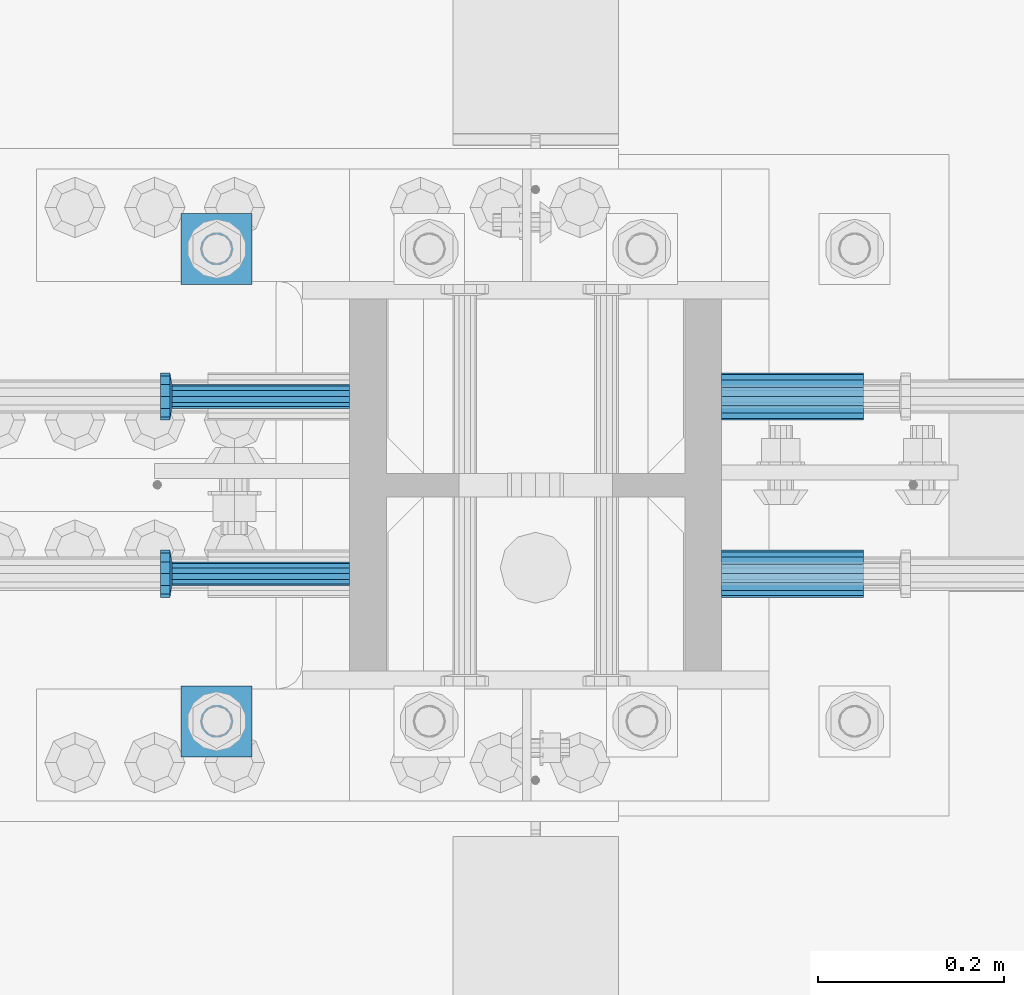
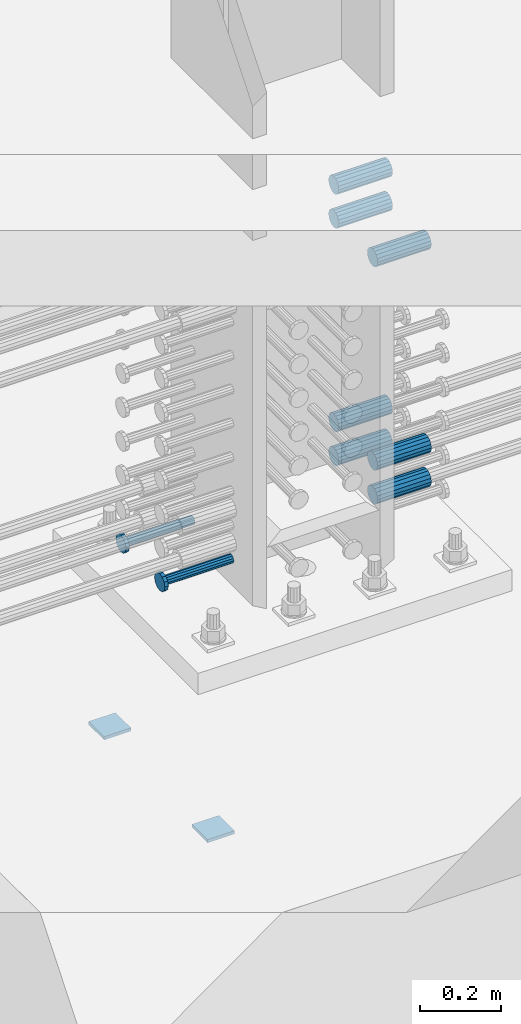
# One storey, part 1239 of 1763: 11 beams, 2 elements without a shape of their own.
"""IFC2X3 building model written with IfcOpenShell, lengths in millimetres."""

from ifc_helpers import new_model, si_unit, frame, origin_with_axes, place, context, subcontext, project, spatial, faceted_brep, material, type_object, element, aggregate, save


model = new_model("IFC2X3")

# Units and contexts
model_context = context("Model", 3, precision=1e-05, world=origin_with_axes())
body_context = subcontext(model_context, "Body", "Model", "MODEL_VIEW")
ifc_project = project(units=[si_unit("LENGTHUNIT", "METRE", prefix="MILLI"), si_unit("AREAUNIT", "SQUARE_METRE"), si_unit("VOLUMEUNIT", "CUBIC_METRE"), si_unit("MASSUNIT", "GRAM", prefix="KILO"), si_unit("TIMEUNIT", "SECOND"), si_unit("PLANEANGLEUNIT", "RADIAN"), si_unit("SOLIDANGLEUNIT", "STERADIAN"), si_unit("THERMODYNAMICTEMPERATUREUNIT", "DEGREE_CELSIUS"), si_unit("LUMINOUSINTENSITYUNIT", "LUMEN")], contexts=[model_context])

# Site, building, storey
site_placement = place(None, origin_with_axes())
site = spatial("IfcSite", under=ifc_project, at=site_placement, CompositionType="ELEMENT")
building_placement = place(site_placement, origin_with_axes())
building = spatial("IfcBuilding", under=site, at=building_placement, Name="Undefined", CompositionType="ELEMENT")
storey_placement = place(building_placement, origin_with_axes())
storey = spatial("IfcBuildingStorey", under=building, at=storey_placement, Name="Undefined", CompositionType="ELEMENT", Elevation=0.0)

# Assembly, beams
assembly_1_placement = place(storey_placement, origin_with_axes())
assembly_1 = element("IfcElementAssembly", 1, at=assembly_1_placement, inside=storey, Name="TEMPLATE", AssemblyPlace="NOTDEFINED", PredefinedType="RIGID_FRAME")
ifc_material_1 = material(Name="STEEL/A36")
beam_type_1 = type_object("IfcBeamType", PredefinedType="NOTDEFINED")
beam_1_placement = place(assembly_1_placement, frame((-35254.637273698, 203.199999999951, 3348.0375), z_axis=(0.0, 1.0, 0.0), x_axis=(-1.0, 0.0, 0.0)))
beam_1 = element("IfcBeam", 2, at=beam_1_placement, type_object=beam_type_1, material=ifc_material_1, Name="WASHER PLATE", context=body_context, shape_type="Brep", body=[
    faceted_brep([(0.0, 4.76249999999709, -38.1000000000004), (0.0, 4.76249999999709, 38.1000000000004), (76.2000000000007, 4.76249999999982, 38.0999999999985), (76.2000000000007, 4.76249999999982, -38.0999999999985), (0.0, -4.76249999999709, 38.1000000000004), (76.2000000000007, -4.76249999999982, 38.0999999999985), (0.0, -4.76249999999709, -38.1000000000004), (76.2000000000007, -4.76249999999982, -38.0999999999985)], [[[0, 1, 2, 3]], [[1, 4, 5, 2]], [[4, 6, 7, 5]], [[6, 0, 3, 7]], [[5, 7, 3, 2]], [[6, 4, 1, 0]]]),
])
beam_2_placement = place(assembly_1_placement, frame((-35254.637273698, 711.199999999951, 3348.0375), z_axis=(0.0, 1.0, 0.0), x_axis=(-1.0, 0.0, 0.0)))
beam_2 = element("IfcBeam", 3, at=beam_2_placement, type_object=beam_type_1, material=ifc_material_1, Name="WASHER PLATE", context=body_context, shape_type="Brep", body=[
    faceted_brep([(0.0, 4.76249999999709, -38.1000000000004), (0.0, 4.76249999999709, 38.1000000000004), (76.2000000000007, 4.76249999999982, 38.0999999999985), (76.2000000000007, 4.76249999999982, -38.0999999999985), (0.0, -4.76249999999709, 38.1000000000004), (76.2000000000007, -4.76249999999982, 38.0999999999985), (0.0, -4.76249999999709, -38.1000000000004), (76.2000000000007, -4.76249999999982, -38.0999999999985)], [[[0, 1, 2, 3]], [[1, 4, 5, 2]], [[4, 6, 7, 5]], [[6, 0, 3, 7]], [[5, 7, 3, 2]], [[6, 4, 1, 0]]]),
])
aggregate(assembly_1, [beam_1, beam_2])

assembly_2_placement = place(storey_placement, origin_with_axes())
assembly_2 = element("IfcElementAssembly", 4, at=assembly_2_placement, inside=storey, Name="COLUMN", AssemblyPlace="NOTDEFINED", PredefinedType="RIGID_FRAME")
ifc_material_2 = material(Name="STEEL/A706-GR.80")
beam_type_2 = type_object("IfcBeamType", PredefinedType="NOTDEFINED")
beam_3_placement = place(assembly_2_placement, frame((-34749.8122049617, 552.450000000255, 4063.99999999999), z_axis=(0.0, 0.0, 1.0), x_axis=(1.0, 0.0, 0.0)))
beam_3 = element("IfcBeam", 5, at=beam_3_placement, type_object=beam_type_2, material=ifc_material_2, Name="HALF COUPLER", context=body_context, shape_type="Brep", body=[
    faceted_brep([(0.0, -25.4000000000015, 0.0), (0.0, -23.466540125788, -9.72015918207308), (152.400103102711, -23.466540125788, -9.72015918207308), (152.400103102711, -25.4000000000015, 0.0), (0.0, -17.9605122421381, -17.9605122421385), (152.400103102711, -17.9605122421381, -17.9605122421385), (0.0, -9.72015918207398, -23.4665401257867), (152.400103102711, -9.72015918207398, -23.4665401257867), (0.0, 0.0, -25.4000000000001), (152.400103102711, 0.0, -25.4000000000001), (0.0, 9.72015918207398, -23.4665401257867), (152.400103102711, 9.72015918207398, -23.4665401257867), (0.0, 17.9605122421381, -17.9605122421385), (152.400103102711, 17.9605122421381, -17.9605122421385), (0.0, 23.466540125788, -9.72015918207308), (152.400103102711, 23.466540125788, -9.72015918207308), (0.0, 25.4000000000015, 0.0), (152.400103102711, 25.4000000000015, 0.0), (0.0, 23.466540125788, 9.72015918207308), (152.400103102711, 23.466540125788, 9.72015918207308), (0.0, 17.9605122421381, 17.9605122421385), (152.400103102711, 17.9605122421381, 17.9605122421385), (0.0, 9.72015918207398, 23.4665401257867), (152.400103102711, 9.72015918207398, 23.4665401257867), (0.0, 0.0, 25.4000000000001), (152.400103102711, 0.0, 25.4000000000001), (0.0, -9.72015918207398, 23.4665401257867), (152.400103102711, -9.72015918207398, 23.4665401257867), (0.0, -17.9605122421381, 17.9605122421385), (152.400103102711, -17.9605122421381, 17.9605122421385), (0.0, -23.466540125788, 9.72015918207308), (152.400103102711, -23.466540125788, 9.72015918207308)], [[[0, 1, 2, 3]], [[1, 4, 5, 2]], [[4, 6, 7, 5]], [[6, 8, 9, 7]], [[8, 10, 11, 9]], [[10, 12, 13, 11]], [[12, 14, 15, 13]], [[14, 16, 17, 15]], [[16, 18, 19, 17]], [[18, 20, 21, 19]], [[20, 22, 23, 21]], [[22, 24, 25, 23]], [[24, 26, 27, 25]], [[26, 28, 29, 27]], [[28, 30, 31, 29]], [[30, 0, 3, 31]], [[5, 7, 9, 11, 13, 15, 17, 19, 21, 23, 25, 27, 29, 31, 3, 2]], [[30, 28, 26, 24, 22, 20, 18, 16, 14, 12, 10, 8, 6, 4, 1, 0]]]),
])
beam_4_placement = place(assembly_2_placement, frame((-34749.8122736235, 361.950000000843, 4063.99999999999), z_axis=(0.0, 0.0, 1.0), x_axis=(1.0, 0.0, 0.0)))
beam_4 = element("IfcBeam", 6, at=beam_4_placement, type_object=beam_type_2, material=ifc_material_2, Name="HALF COUPLER F", context=body_context, shape_type="Brep", body=[
    faceted_brep([(32.7659999999996, -8.95349999999962, -15.507916905568), (32.7659999999996, 0.0, -17.9070000000002), (32.7659999999996, 8.95349999999962, -15.507916905568), (32.7659999999996, 15.507916905568, -8.95350000000008), (32.7659999999996, 17.9069999999992, 0.0), (32.7659999999996, 15.507916905568, 8.95350000000008), (32.7659999999996, 8.95349999999962, 15.507916905568), (32.7659999999996, 0.0, 17.9070000000002), (32.7659999999996, -8.95349999999962, 15.507916905568), (32.7659999999996, -15.507916905568, 8.95350000000008), (32.7659999999996, -17.9069999999992, 0.0), (32.7659999999996, -15.507916905568, -8.95350000000008), (152.400103102711, -15.507916905568, 8.95350000000008), (152.400103102711, -8.95349999999962, 15.507916905568), (152.400103102711, -17.9069999999992, 0.0), (152.400103102711, -15.507916905568, -8.95350000000008), (152.400103102711, -8.95349999999962, -15.507916905568), (152.400103102711, 0.0, -17.9070000000002), (152.400103102711, 8.95349999999962, -15.507916905568), (152.400103102711, 15.507916905568, -8.95350000000008), (152.400103102711, 17.9069999999992, 0.0), (152.400103102711, 15.507916905568, 8.95350000000008), (152.400103102711, 8.95349999999962, 15.507916905568), (152.400103102711, 0.0, 17.9070000000002), (0.0, -23.466540125788, 9.72015918207308), (0.0, -17.9605122421381, 17.9605122421385), (0.0, -9.72015918207398, 23.4665401257867), (0.0, 0.0, 25.4000000000001), (0.0, 9.72015918207398, 23.4665401257867), (0.0, 17.9605122421381, 17.9605122421385), (0.0, 23.466540125788, 9.72015918207308), (0.0, 25.4000000000015, 0.0), (0.0, 23.466540125788, -9.72015918207308), (0.0, 17.9605122421381, -17.9605122421385), (0.0, 9.72015918207398, -23.4665401257867), (0.0, 0.0, -25.4000000000001), (0.0, -9.72015918207398, -23.4665401257867), (0.0, -17.9605122421381, -17.9605122421385), (0.0, -23.466540125788, -9.72015918207308), (0.0, -25.4000000000015, 0.0), (152.400103102711, -25.4000000000015, 0.0), (152.400103102711, -23.466540125788, 9.72015918207308), (152.400103102711, -17.9605122421381, 17.9605122421385), (152.400103102711, -9.72015918207398, 23.4665401257867), (152.400103102711, 0.0, 25.4000000000001), (152.400103102711, 9.72015918207398, 23.4665401257867), (152.400103102711, 17.9605122421381, 17.9605122421385), (152.400103102711, 23.466540125788, 9.72015918207308), (152.400103102711, 25.4000000000015, 0.0), (152.400103102711, 23.466540125788, -9.72015918207308), (152.400103102711, 17.9605122421381, -17.9605122421385), (152.400103102711, 9.72015918207398, -23.4665401257867), (152.400103102711, 0.0, -25.4000000000001), (152.400103102711, -9.72015918207398, -23.4665401257867), (152.400103102711, -17.9605122421381, -17.9605122421385), (152.400103102711, -23.466540125788, -9.72015918207308)], [[[0, 1, 2, 3, 4, 5, 6, 7, 8, 9, 10, 11]], [[12, 9, 8, 13]], [[14, 10, 9, 12]], [[15, 11, 10, 14]], [[16, 0, 11, 15]], [[17, 1, 0, 16]], [[18, 2, 1, 17]], [[19, 3, 2, 18]], [[20, 4, 3, 19]], [[21, 5, 4, 20]], [[22, 6, 5, 21]], [[23, 7, 6, 22]], [[13, 8, 7, 23]], [[24, 25, 26, 27, 28, 29, 30, 31, 32, 33, 34, 35, 36, 37, 38, 39]], [[24, 39, 40, 41]], [[25, 24, 41, 42]], [[26, 25, 42, 43]], [[27, 26, 43, 44]], [[28, 27, 44, 45]], [[29, 28, 45, 46]], [[30, 29, 46, 47]], [[31, 30, 47, 48]], [[32, 31, 48, 49]], [[33, 32, 49, 50]], [[34, 33, 50, 51]], [[35, 34, 51, 52]], [[36, 35, 52, 53]], [[37, 36, 53, 54]], [[38, 37, 54, 55]], [[39, 38, 55, 40]], [[54, 53, 52, 51, 50, 49, 48, 47, 46, 45, 44, 43, 42, 41, 40, 55], [21, 20, 19, 18, 17, 16, 15, 14, 12, 13, 23, 22]]]),
])
beam_5_placement = place(assembly_2_placement, frame((-34749.8122049618, 552.450000000255, 4165.60000000002), z_axis=(0.0, 0.0, 1.0), x_axis=(1.0, 0.0, 0.0)))
beam_5 = element("IfcBeam", 7, at=beam_5_placement, type_object=beam_type_2, material=ifc_material_2, Name="HALF COUPLER", context=body_context, shape_type="Brep", body=[
    faceted_brep([(0.0, -25.4000000000015, 0.0), (0.0, -23.466540125788, -9.72015918207308), (152.400103102711, -23.466540125788, -9.72015918207308), (152.400103102711, -25.4000000000015, 0.0), (0.0, -17.9605122421381, -17.9605122421385), (152.400103102711, -17.9605122421381, -17.9605122421385), (0.0, -9.72015918207398, -23.4665401257867), (152.400103102711, -9.72015918207398, -23.4665401257867), (0.0, 0.0, -25.4000000000001), (152.400103102711, 0.0, -25.4000000000001), (0.0, 9.72015918207398, -23.4665401257867), (152.400103102711, 9.72015918207398, -23.4665401257867), (0.0, 17.9605122421381, -17.9605122421385), (152.400103102711, 17.9605122421381, -17.9605122421385), (0.0, 23.466540125788, -9.72015918207308), (152.400103102711, 23.466540125788, -9.72015918207308), (0.0, 25.4000000000015, 0.0), (152.400103102711, 25.4000000000015, 0.0), (0.0, 23.466540125788, 9.72015918207308), (152.400103102711, 23.466540125788, 9.72015918207308), (0.0, 17.9605122421381, 17.9605122421385), (152.400103102711, 17.9605122421381, 17.9605122421385), (0.0, 9.72015918207398, 23.4665401257867), (152.400103102711, 9.72015918207398, 23.4665401257867), (0.0, 0.0, 25.4000000000001), (152.400103102711, 0.0, 25.4000000000001), (0.0, -9.72015918207398, 23.4665401257867), (152.400103102711, -9.72015918207398, 23.4665401257867), (0.0, -17.9605122421381, 17.9605122421385), (152.400103102711, -17.9605122421381, 17.9605122421385), (0.0, -23.466540125788, 9.72015918207308), (152.400103102711, -23.466540125788, 9.72015918207308)], [[[0, 1, 2, 3]], [[1, 4, 5, 2]], [[4, 6, 7, 5]], [[6, 8, 9, 7]], [[8, 10, 11, 9]], [[10, 12, 13, 11]], [[12, 14, 15, 13]], [[14, 16, 17, 15]], [[16, 18, 19, 17]], [[18, 20, 21, 19]], [[20, 22, 23, 21]], [[22, 24, 25, 23]], [[24, 26, 27, 25]], [[26, 28, 29, 27]], [[28, 30, 31, 29]], [[30, 0, 3, 31]], [[5, 7, 9, 11, 13, 15, 17, 19, 21, 23, 25, 27, 29, 31, 3, 2]], [[30, 28, 26, 24, 22, 20, 18, 16, 14, 12, 10, 8, 6, 4, 1, 0]]]),
])
beam_6_placement = place(assembly_2_placement, frame((-34749.8122736236, 361.950000000843, 4165.60000000002), z_axis=(0.0, 0.0, 1.0), x_axis=(1.0, 0.0, 0.0)))
beam_6 = element("IfcBeam", 8, at=beam_6_placement, type_object=beam_type_2, material=ifc_material_2, Name="HALF COUPLER F", context=body_context, shape_type="Brep", body=[
    faceted_brep([(32.7659999999996, -8.95349999999962, -15.507916905568), (32.7659999999996, 0.0, -17.9070000000002), (32.7659999999996, 8.95349999999962, -15.507916905568), (32.7659999999996, 15.507916905568, -8.95350000000008), (32.7659999999996, 17.9069999999992, 0.0), (32.7659999999996, 15.507916905568, 8.95350000000008), (32.7659999999996, 8.95349999999962, 15.507916905568), (32.7659999999996, 0.0, 17.9070000000002), (32.7659999999996, -8.95349999999962, 15.507916905568), (32.7659999999996, -15.507916905568, 8.95350000000008), (32.7659999999996, -17.9069999999992, 0.0), (32.7659999999996, -15.507916905568, -8.95350000000008), (152.400103102711, -15.507916905568, 8.95350000000008), (152.400103102711, -8.95349999999962, 15.507916905568), (152.400103102711, -17.9069999999992, 0.0), (152.400103102711, -15.507916905568, -8.95350000000008), (152.400103102711, -8.95349999999962, -15.507916905568), (152.400103102711, 0.0, -17.9070000000002), (152.400103102711, 8.95349999999962, -15.507916905568), (152.400103102711, 15.507916905568, -8.95350000000008), (152.400103102711, 17.9069999999992, 0.0), (152.400103102711, 15.507916905568, 8.95350000000008), (152.400103102711, 8.95349999999962, 15.507916905568), (152.400103102711, 0.0, 17.9070000000002), (0.0, -23.466540125788, 9.72015918207308), (0.0, -17.9605122421381, 17.9605122421385), (0.0, -9.72015918207398, 23.4665401257867), (0.0, 0.0, 25.4000000000001), (0.0, 9.72015918207398, 23.4665401257867), (0.0, 17.9605122421381, 17.9605122421385), (0.0, 23.466540125788, 9.72015918207308), (0.0, 25.4000000000015, 0.0), (0.0, 23.466540125788, -9.72015918207308), (0.0, 17.9605122421381, -17.9605122421385), (0.0, 9.72015918207398, -23.4665401257867), (0.0, 0.0, -25.4000000000001), (0.0, -9.72015918207398, -23.4665401257867), (0.0, -17.9605122421381, -17.9605122421385), (0.0, -23.466540125788, -9.72015918207308), (0.0, -25.4000000000015, 0.0), (152.400103102711, -25.4000000000015, 0.0), (152.400103102711, -23.466540125788, 9.72015918207308), (152.400103102711, -17.9605122421381, 17.9605122421385), (152.400103102711, -9.72015918207398, 23.4665401257867), (152.400103102711, 0.0, 25.4000000000001), (152.400103102711, 9.72015918207398, 23.4665401257867), (152.400103102711, 17.9605122421381, 17.9605122421385), (152.400103102711, 23.466540125788, 9.72015918207308), (152.400103102711, 25.4000000000015, 0.0), (152.400103102711, 23.466540125788, -9.72015918207308), (152.400103102711, 17.9605122421381, -17.9605122421385), (152.400103102711, 9.72015918207398, -23.4665401257867), (152.400103102711, 0.0, -25.4000000000001), (152.400103102711, -9.72015918207398, -23.4665401257867), (152.400103102711, -17.9605122421381, -17.9605122421385), (152.400103102711, -23.466540125788, -9.72015918207308)], [[[0, 1, 2, 3, 4, 5, 6, 7, 8, 9, 10, 11]], [[12, 9, 8, 13]], [[14, 10, 9, 12]], [[15, 11, 10, 14]], [[16, 0, 11, 15]], [[17, 1, 0, 16]], [[18, 2, 1, 17]], [[19, 3, 2, 18]], [[20, 4, 3, 19]], [[21, 5, 4, 20]], [[22, 6, 5, 21]], [[23, 7, 6, 22]], [[13, 8, 7, 23]], [[24, 25, 26, 27, 28, 29, 30, 31, 32, 33, 34, 35, 36, 37, 38, 39]], [[24, 39, 40, 41]], [[25, 24, 41, 42]], [[26, 25, 42, 43]], [[27, 26, 43, 44]], [[28, 27, 44, 45]], [[29, 28, 45, 46]], [[30, 29, 46, 47]], [[31, 30, 47, 48]], [[32, 31, 48, 49]], [[33, 32, 49, 50]], [[34, 33, 50, 51]], [[35, 34, 51, 52]], [[36, 35, 52, 53]], [[37, 36, 53, 54]], [[38, 37, 54, 55]], [[39, 38, 55, 40]], [[54, 53, 52, 51, 50, 49, 48, 47, 46, 45, 44, 43, 42, 41, 40, 55], [21, 20, 19, 18, 17, 16, 15, 14, 12, 13, 23, 22]]]),
])
beam_7_placement = place(assembly_2_placement, frame((-34749.8122736972, 552.450000000255, 4775.20000000008), z_axis=(0.0, 0.0, 1.0), x_axis=(1.0, 0.0, 0.0)))
beam_7 = element("IfcBeam", 9, at=beam_7_placement, type_object=beam_type_2, material=ifc_material_2, Name="HALF COUPLER", context=body_context, shape_type="Brep", body=[
    faceted_brep([(0.0, -25.4000000000015, 0.0), (0.0, -23.466540125788, -9.72015918207308), (152.400103102711, -23.466540125788, -9.72015918207308), (152.400103102711, -25.4000000000015, 0.0), (0.0, -17.9605122421381, -17.9605122421385), (152.400103102711, -17.9605122421381, -17.9605122421385), (0.0, -9.72015918207398, -23.4665401257867), (152.400103102711, -9.72015918207398, -23.4665401257867), (0.0, 0.0, -25.4000000000001), (152.400103102711, 0.0, -25.4000000000001), (0.0, 9.72015918207398, -23.4665401257867), (152.400103102711, 9.72015918207398, -23.4665401257867), (0.0, 17.9605122421381, -17.9605122421385), (152.400103102711, 17.9605122421381, -17.9605122421385), (0.0, 23.466540125788, -9.72015918207308), (152.400103102711, 23.466540125788, -9.72015918207308), (0.0, 25.4000000000015, 0.0), (152.400103102711, 25.4000000000015, 0.0), (0.0, 23.466540125788, 9.72015918207308), (152.400103102711, 23.466540125788, 9.72015918207308), (0.0, 17.9605122421381, 17.9605122421385), (152.400103102711, 17.9605122421381, 17.9605122421385), (0.0, 9.72015918207398, 23.4665401257867), (152.400103102711, 9.72015918207398, 23.4665401257867), (0.0, 0.0, 25.4000000000001), (152.400103102711, 0.0, 25.4000000000001), (0.0, -9.72015918207398, 23.4665401257867), (152.400103102711, -9.72015918207398, 23.4665401257867), (0.0, -17.9605122421381, 17.9605122421385), (152.400103102711, -17.9605122421381, 17.9605122421385), (0.0, -23.466540125788, 9.72015918207308), (152.400103102711, -23.466540125788, 9.72015918207308)], [[[0, 1, 2, 3]], [[1, 4, 5, 2]], [[4, 6, 7, 5]], [[6, 8, 9, 7]], [[8, 10, 11, 9]], [[10, 12, 13, 11]], [[12, 14, 15, 13]], [[14, 16, 17, 15]], [[16, 18, 19, 17]], [[18, 20, 21, 19]], [[20, 22, 23, 21]], [[22, 24, 25, 23]], [[24, 26, 27, 25]], [[26, 28, 29, 27]], [[28, 30, 31, 29]], [[30, 0, 3, 31]], [[5, 7, 9, 11, 13, 15, 17, 19, 21, 23, 25, 27, 29, 31, 3, 2]], [[30, 28, 26, 24, 22, 20, 18, 16, 14, 12, 10, 8, 6, 4, 1, 0]]]),
])
beam_8_placement = place(assembly_2_placement, frame((-34749.812342359, 361.950000000843, 4775.20000000008), z_axis=(0.0, 0.0, 1.0), x_axis=(1.0, 0.0, 0.0)))
beam_8 = element("IfcBeam", 10, at=beam_8_placement, type_object=beam_type_2, material=ifc_material_2, Name="HALF COUPLER F", context=body_context, shape_type="Brep", body=[
    faceted_brep([(32.7659999999996, -8.95349999999962, -15.507916905568), (32.7659999999996, 0.0, -17.9070000000002), (32.7659999999996, 8.95349999999962, -15.507916905568), (32.7659999999996, 15.507916905568, -8.95350000000008), (32.7659999999996, 17.9069999999992, 0.0), (32.7659999999996, 15.507916905568, 8.95350000000008), (32.7659999999996, 8.95349999999962, 15.507916905568), (32.7659999999996, 0.0, 17.9070000000002), (32.7659999999996, -8.95349999999962, 15.507916905568), (32.7659999999996, -15.507916905568, 8.95350000000008), (32.7659999999996, -17.9069999999992, 0.0), (32.7659999999996, -15.507916905568, -8.95350000000008), (152.400103102711, -15.507916905568, 8.95350000000008), (152.400103102711, -8.95349999999962, 15.507916905568), (152.400103102711, -17.9069999999992, 0.0), (152.400103102711, -15.507916905568, -8.95350000000008), (152.400103102711, -8.95349999999962, -15.507916905568), (152.400103102711, 0.0, -17.9070000000002), (152.400103102711, 8.95349999999962, -15.507916905568), (152.400103102711, 15.507916905568, -8.95350000000008), (152.400103102711, 17.9069999999992, 0.0), (152.400103102711, 15.507916905568, 8.95350000000008), (152.400103102711, 8.95349999999962, 15.507916905568), (152.400103102711, 0.0, 17.9070000000002), (0.0, -23.466540125788, 9.72015918207308), (0.0, -17.9605122421381, 17.9605122421385), (0.0, -9.72015918207398, 23.4665401257867), (0.0, 0.0, 25.4000000000001), (0.0, 9.72015918207398, 23.4665401257867), (0.0, 17.9605122421381, 17.9605122421385), (0.0, 23.466540125788, 9.72015918207308), (0.0, 25.4000000000015, 0.0), (0.0, 23.466540125788, -9.72015918207308), (0.0, 17.9605122421381, -17.9605122421385), (0.0, 9.72015918207398, -23.4665401257867), (0.0, 0.0, -25.4000000000001), (0.0, -9.72015918207398, -23.4665401257867), (0.0, -17.9605122421381, -17.9605122421385), (0.0, -23.466540125788, -9.72015918207308), (0.0, -25.4000000000015, 0.0), (152.400103102711, -25.4000000000015, 0.0), (152.400103102711, -23.466540125788, 9.72015918207308), (152.400103102711, -17.9605122421381, 17.9605122421385), (152.400103102711, -9.72015918207398, 23.4665401257867), (152.400103102711, 0.0, 25.4000000000001), (152.400103102711, 9.72015918207398, 23.4665401257867), (152.400103102711, 17.9605122421381, 17.9605122421385), (152.400103102711, 23.466540125788, 9.72015918207308), (152.400103102711, 25.4000000000015, 0.0), (152.400103102711, 23.466540125788, -9.72015918207308), (152.400103102711, 17.9605122421381, -17.9605122421385), (152.400103102711, 9.72015918207398, -23.4665401257867), (152.400103102711, 0.0, -25.4000000000001), (152.400103102711, -9.72015918207398, -23.4665401257867), (152.400103102711, -17.9605122421381, -17.9605122421385), (152.400103102711, -23.466540125788, -9.72015918207308)], [[[0, 1, 2, 3, 4, 5, 6, 7, 8, 9, 10, 11]], [[12, 9, 8, 13]], [[14, 10, 9, 12]], [[15, 11, 10, 14]], [[16, 0, 11, 15]], [[17, 1, 0, 16]], [[18, 2, 1, 17]], [[19, 3, 2, 18]], [[20, 4, 3, 19]], [[21, 5, 4, 20]], [[22, 6, 5, 21]], [[23, 7, 6, 22]], [[13, 8, 7, 23]], [[24, 25, 26, 27, 28, 29, 30, 31, 32, 33, 34, 35, 36, 37, 38, 39]], [[24, 39, 40, 41]], [[25, 24, 41, 42]], [[26, 25, 42, 43]], [[27, 26, 43, 44]], [[28, 27, 44, 45]], [[29, 28, 45, 46]], [[30, 29, 46, 47]], [[31, 30, 47, 48]], [[32, 31, 48, 49]], [[33, 32, 49, 50]], [[34, 33, 50, 51]], [[35, 34, 51, 52]], [[36, 35, 52, 53]], [[37, 36, 53, 54]], [[38, 37, 54, 55]], [[39, 38, 55, 40]], [[54, 53, 52, 51, 50, 49, 48, 47, 46, 45, 44, 43, 42, 41, 40, 55], [21, 20, 19, 18, 17, 16, 15, 14, 12, 13, 23, 22]]]),
])
beam_9_placement = place(assembly_2_placement, frame((-34749.8122736972, 552.450000000255, 4876.80000000008), z_axis=(0.0, 0.0, 1.0), x_axis=(1.0, 0.0, 0.0)))
beam_9 = element("IfcBeam", 11, at=beam_9_placement, type_object=beam_type_2, material=ifc_material_2, Name="HALF COUPLER", context=body_context, shape_type="Brep", body=[
    faceted_brep([(0.0, -25.4000000000015, 0.0), (0.0, -23.466540125788, -9.72015918207308), (152.400103102711, -23.466540125788, -9.72015918207308), (152.400103102711, -25.4000000000015, 0.0), (0.0, -17.9605122421381, -17.9605122421385), (152.400103102711, -17.9605122421381, -17.9605122421385), (0.0, -9.72015918207398, -23.4665401257867), (152.400103102711, -9.72015918207398, -23.4665401257867), (0.0, 0.0, -25.4000000000001), (152.400103102711, 0.0, -25.4000000000001), (0.0, 9.72015918207398, -23.4665401257867), (152.400103102711, 9.72015918207398, -23.4665401257867), (0.0, 17.9605122421381, -17.9605122421385), (152.400103102711, 17.9605122421381, -17.9605122421385), (0.0, 23.466540125788, -9.72015918207308), (152.400103102711, 23.466540125788, -9.72015918207308), (0.0, 25.4000000000015, 0.0), (152.400103102711, 25.4000000000015, 0.0), (0.0, 23.466540125788, 9.72015918207308), (152.400103102711, 23.466540125788, 9.72015918207308), (0.0, 17.9605122421381, 17.9605122421385), (152.400103102711, 17.9605122421381, 17.9605122421385), (0.0, 9.72015918207398, 23.4665401257867), (152.400103102711, 9.72015918207398, 23.4665401257867), (0.0, 0.0, 25.4000000000001), (152.400103102711, 0.0, 25.4000000000001), (0.0, -9.72015918207398, 23.4665401257867), (152.400103102711, -9.72015918207398, 23.4665401257867), (0.0, -17.9605122421381, 17.9605122421385), (152.400103102711, -17.9605122421381, 17.9605122421385), (0.0, -23.466540125788, 9.72015918207308), (152.400103102711, -23.466540125788, 9.72015918207308)], [[[0, 1, 2, 3]], [[1, 4, 5, 2]], [[4, 6, 7, 5]], [[6, 8, 9, 7]], [[8, 10, 11, 9]], [[10, 12, 13, 11]], [[12, 14, 15, 13]], [[14, 16, 17, 15]], [[16, 18, 19, 17]], [[18, 20, 21, 19]], [[20, 22, 23, 21]], [[22, 24, 25, 23]], [[24, 26, 27, 25]], [[26, 28, 29, 27]], [[28, 30, 31, 29]], [[30, 0, 3, 31]], [[5, 7, 9, 11, 13, 15, 17, 19, 21, 23, 25, 27, 29, 31, 3, 2]], [[30, 28, 26, 24, 22, 20, 18, 16, 14, 12, 10, 8, 6, 4, 1, 0]]]),
])
ifc_material_3 = material(Name="STEEL/A108")
beam_type_3 = type_object("IfcBeamType", PredefinedType="NOTDEFINED")
beam_10_placement = place(assembly_2_placement, frame((-35149.8622049631, 361.949999999943, 4013.2), z_axis=(0.0, 1.0, 0.0), x_axis=(-1.0, 0.0, 0.0)))
beam_10 = element("IfcBeam", 12, at=beam_10_placement, type_object=beam_type_3, material=ifc_material_3, Name="HEADED STUD ANCHOR", context=body_context, shape_type="Brep", body=[
    faceted_brep([(0.0, -12.6999999999971, -1.81898940354586e-12), (3.63797880709171e-12, -11.0, -6.34999990463257), (191.00799999576, -11.0, -6.34999990454889), (191.007999995752, -12.6999998092651, 8.36735125631094e-11), (7.27595761418343e-12, -6.34999990463257, -11.0), (191.00799999576, -6.34999990463257, -10.9999999999163), (3.63797880709171e-12, 0.0, -12.6999998092651), (191.00799999576, 0.0, -12.6999998091815), (7.27595761418343e-12, 6.34999990463257, -11.0), (191.00799999576, 6.34999990463257, -10.9999999999163), (3.63797880709171e-12, 11.0, -6.34999990463257), (191.00799999576, 11.0, -6.34999990454889), (0.0, 12.6999999999971, -1.81898940354586e-12), (191.007999995752, 12.6999998092651, 8.36735125631094e-11), (0.0, 11.0, 6.34999990463257), (191.007999995752, 11.0, 6.34999990471624), (-3.63797880709171e-12, 6.34999990463257, 11.0), (191.007999995749, 6.34999990463257, 11.0000000000837), (-3.63797880709171e-12, 0.0, 12.6999998092651), (191.007999995749, 0.0, 12.6999998093488), (-3.63797880709171e-12, -6.34999990463257, 11.0), (191.007999995749, -6.34999990463257, 11.0000000000837), (0.0, -11.0, 6.34999990463257), (191.007999995752, -11.0, 6.34999990471624), (193.039999995715, -22.0, -12.6999998091796), (193.039999995708, -25.3999996185303, 8.54925019666553e-11), (193.039999995719, -12.6999998092651, -21.9999999999145), (193.039999995719, 0.0, -25.3999996184448), (193.039999995719, 12.6999998092651, -21.9999999999145), (193.039999995715, 22.0, -12.6999998091796), (193.039999995708, 25.3999996185303, 8.54925019666553e-11), (193.039999995704, 22.0, 12.6999998093506), (193.039999995701, 12.6999998092651, 22.0000000000855), (193.039999995697, 0.0, 25.3999996186158), (193.039999995701, -12.6999998092651, 22.0000000000855), (193.039999995704, -22.0, 12.6999998093506), (203.199999995486, -22.0, -12.6999998091742), (203.199999995482, -25.3999996185303, 9.09494701772928e-11), (203.199999995493, -12.6999998092651, -21.9999999999091), (203.199999995493, 0.0, -25.3999996184393), (203.199999995493, 12.6999998092651, -21.9999999999091), (203.199999995486, 22.0, -12.6999998091742), (203.199999995482, 25.3999996185303, 9.09494701772928e-11), (203.199999995479, 22.0, 12.6999998093561), (203.199999995475, 12.6999998092651, 22.0000000000909), (203.199999995471, 0.0, 25.3999996186212), (203.199999995475, -12.6999998092651, 22.0000000000909), (203.199999995479, -22.0, 12.6999998093561)], [[[0, 1, 2, 3]], [[1, 4, 5, 2]], [[4, 6, 7, 5]], [[6, 8, 9, 7]], [[8, 10, 11, 9]], [[10, 12, 13, 11]], [[12, 14, 15, 13]], [[14, 16, 17, 15]], [[16, 18, 19, 17]], [[18, 20, 21, 19]], [[20, 22, 23, 21]], [[22, 0, 3, 23]], [[22, 20, 18, 16, 14, 12, 10, 8, 6, 4, 1, 0]], [[3, 2, 24, 25]], [[2, 5, 26, 24]], [[5, 7, 27, 26]], [[7, 9, 28, 27]], [[9, 11, 29, 28]], [[11, 13, 30, 29]], [[13, 15, 31, 30]], [[15, 17, 32, 31]], [[17, 19, 33, 32]], [[19, 21, 34, 33]], [[21, 23, 35, 34]], [[23, 3, 25, 35]], [[25, 24, 36, 37]], [[24, 26, 38, 36]], [[26, 27, 39, 38]], [[27, 28, 40, 39]], [[28, 29, 41, 40]], [[29, 30, 42, 41]], [[30, 31, 43, 42]], [[31, 32, 44, 43]], [[32, 33, 45, 44]], [[33, 34, 46, 45]], [[34, 35, 47, 46]], [[35, 25, 37, 47]], [[38, 39, 40, 41, 42, 43, 44, 45, 46, 47, 37, 36]]]),
])
beam_11_placement = place(assembly_2_placement, frame((-35149.8621362276, 552.449999999768, 4013.2), z_axis=(0.0, 1.0, 0.0), x_axis=(-1.0, 0.0, 0.0)))
beam_11 = element("IfcBeam", 13, at=beam_11_placement, type_object=beam_type_3, material=ifc_material_3, Name="HEADED STUD ANCHOR", context=body_context, shape_type="Brep", body=[
    faceted_brep([(0.0, -12.6999999999971, -1.81898940354586e-12), (3.63797880709171e-12, -11.0, -6.34999990463257), (191.00799999576, -11.0, -6.34999990454889), (191.007999995752, -12.6999998092651, 8.36735125631094e-11), (7.27595761418343e-12, -6.34999990463257, -11.0), (191.00799999576, -6.34999990463257, -10.9999999999163), (3.63797880709171e-12, 0.0, -12.6999998092651), (191.00799999576, 0.0, -12.6999998091815), (7.27595761418343e-12, 6.34999990463257, -11.0), (191.00799999576, 6.34999990463257, -10.9999999999163), (3.63797880709171e-12, 11.0, -6.34999990463257), (191.00799999576, 11.0, -6.34999990454889), (0.0, 12.6999999999971, -1.81898940354586e-12), (191.007999995752, 12.6999998092651, 8.36735125631094e-11), (0.0, 11.0, 6.34999990463257), (191.007999995752, 11.0, 6.34999990471624), (-3.63797880709171e-12, 6.34999990463257, 11.0), (191.007999995749, 6.34999990463257, 11.0000000000837), (-3.63797880709171e-12, 0.0, 12.6999998092651), (191.007999995749, 0.0, 12.6999998093488), (-3.63797880709171e-12, -6.34999990463257, 11.0), (191.007999995749, -6.34999990463257, 11.0000000000837), (0.0, -11.0, 6.34999990463257), (191.007999995752, -11.0, 6.34999990471624), (193.039999995715, -22.0, -12.6999998091796), (193.039999995708, -25.3999996185303, 8.54925019666553e-11), (193.039999995719, -12.6999998092651, -21.9999999999145), (193.039999995719, 0.0, -25.3999996184448), (193.039999995719, 12.6999998092651, -21.9999999999145), (193.039999995715, 22.0, -12.6999998091796), (193.039999995708, 25.3999996185303, 8.54925019666553e-11), (193.039999995704, 22.0, 12.6999998093506), (193.039999995701, 12.6999998092651, 22.0000000000855), (193.039999995697, 0.0, 25.3999996186158), (193.039999995701, -12.6999998092651, 22.0000000000855), (193.039999995704, -22.0, 12.6999998093506), (203.199999995486, -22.0, -12.6999998091742), (203.199999995482, -25.3999996185303, 9.09494701772928e-11), (203.199999995493, -12.6999998092651, -21.9999999999091), (203.199999995493, 0.0, -25.3999996184393), (203.199999995493, 12.6999998092651, -21.9999999999091), (203.199999995486, 22.0, -12.6999998091742), (203.199999995482, 25.3999996185303, 9.09494701772928e-11), (203.199999995479, 22.0, 12.6999998093561), (203.199999995475, 12.6999998092651, 22.0000000000909), (203.199999995471, 0.0, 25.3999996186212), (203.199999995475, -12.6999998092651, 22.0000000000909), (203.199999995479, -22.0, 12.6999998093561)], [[[0, 1, 2, 3]], [[1, 4, 5, 2]], [[4, 6, 7, 5]], [[6, 8, 9, 7]], [[8, 10, 11, 9]], [[10, 12, 13, 11]], [[12, 14, 15, 13]], [[14, 16, 17, 15]], [[16, 18, 19, 17]], [[18, 20, 21, 19]], [[20, 22, 23, 21]], [[22, 0, 3, 23]], [[22, 20, 18, 16, 14, 12, 10, 8, 6, 4, 1, 0]], [[3, 2, 24, 25]], [[2, 5, 26, 24]], [[5, 7, 27, 26]], [[7, 9, 28, 27]], [[9, 11, 29, 28]], [[11, 13, 30, 29]], [[13, 15, 31, 30]], [[15, 17, 32, 31]], [[17, 19, 33, 32]], [[19, 21, 34, 33]], [[21, 23, 35, 34]], [[23, 3, 25, 35]], [[25, 24, 36, 37]], [[24, 26, 38, 36]], [[26, 27, 39, 38]], [[27, 28, 40, 39]], [[28, 29, 41, 40]], [[29, 30, 42, 41]], [[30, 31, 43, 42]], [[31, 32, 44, 43]], [[32, 33, 45, 44]], [[33, 34, 46, 45]], [[34, 35, 47, 46]], [[35, 25, 37, 47]], [[38, 39, 40, 41, 42, 43, 44, 45, 46, 47, 37, 36]]]),
])
aggregate(assembly_2, [beam_3, beam_4, beam_5, beam_6, beam_7, beam_8, beam_9, beam_10, beam_11])

save(model, "model.ifc")
